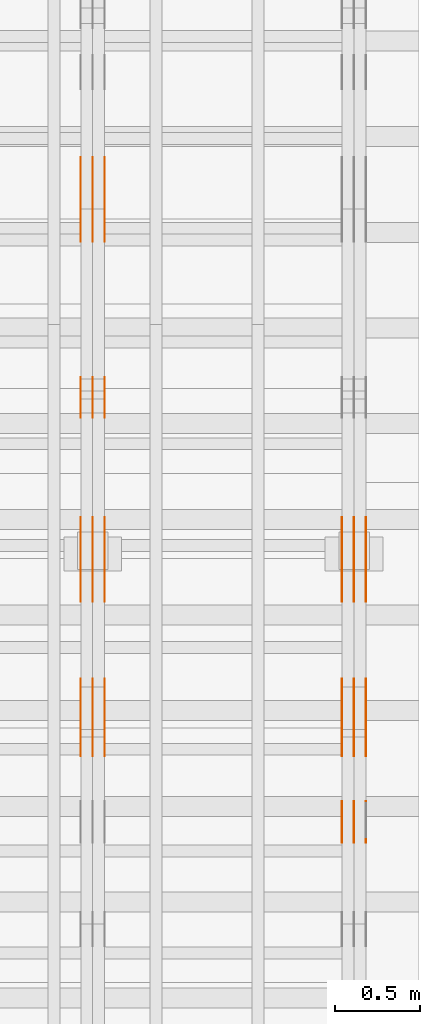
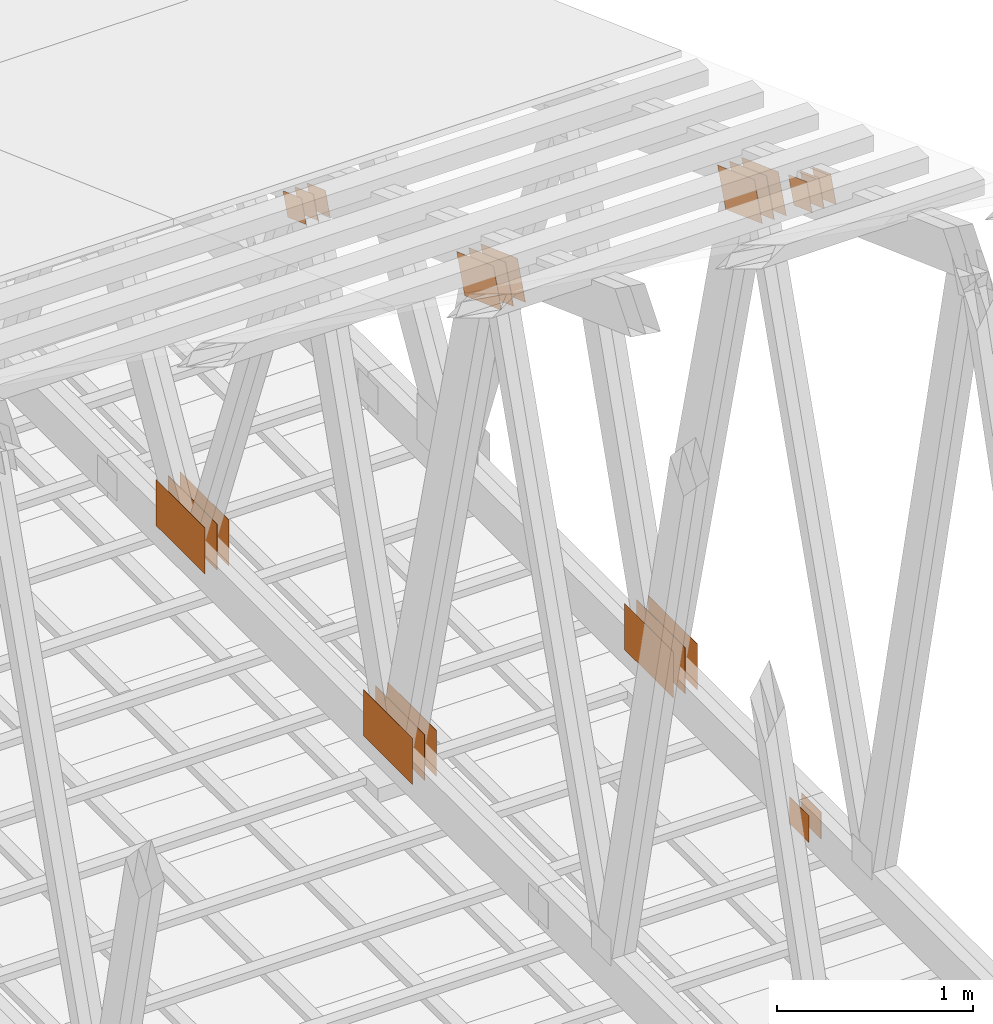
# One storey, part 174 of 189: 31 proxies.
"""IFC2X3 building model written with IfcOpenShell, lengths in millimetres."""

from ifc_helpers import new_model, entity, si_unit, converted_unit, derived_unit, direction, frame, origin, origin_2d_with_axis, place, context, subcontext, project, spatial, polyline, rectangle, outline, extrude, source, transform, mapped, material, type_object, type_shapes, element, save


model = new_model("IFC2X3")

# Units and contexts
model_context = context("Model", 3, precision=0.01, world=origin(), true_north=direction((6.12303176911189e-17, 1.0)))
body_context = subcontext(model_context, "Body", "Model", "MODEL_VIEW")
ifc_project = project(units=[si_unit("LENGTHUNIT", "METRE", prefix="MILLI"), si_unit("AREAUNIT", "SQUARE_METRE"), si_unit("VOLUMEUNIT", "CUBIC_METRE"), converted_unit("PLANEANGLEUNIT", "DEGREE", entity("IfcRatioMeasure", 0.0174532925199433), si_unit("PLANEANGLEUNIT", "RADIAN"), dimensions=[0, 0, 0, 0, 0, 0, 0]), si_unit("MASSUNIT", "GRAM", prefix="KILO"), derived_unit("MASSDENSITYUNIT", [(si_unit("MASSUNIT", "GRAM", prefix="KILO"), 1), (si_unit("LENGTHUNIT", "METRE"), -3)]), si_unit("TIMEUNIT", "SECOND"), si_unit("FREQUENCYUNIT", "HERTZ"), si_unit("THERMODYNAMICTEMPERATUREUNIT", "DEGREE_CELSIUS"), derived_unit("THERMALTRANSMITTANCEUNIT", [(si_unit("MASSUNIT", "GRAM", prefix="KILO"), 1), (si_unit("THERMODYNAMICTEMPERATUREUNIT", "KELVIN"), -1), (si_unit("TIMEUNIT", "SECOND"), -3)]), derived_unit("VOLUMETRICFLOWRATEUNIT", [(si_unit("LENGTHUNIT", "METRE"), 3), (si_unit("TIMEUNIT", "SECOND"), -1)]), si_unit("ELECTRICCURRENTUNIT", "AMPERE"), si_unit("ELECTRICVOLTAGEUNIT", "VOLT"), si_unit("POWERUNIT", "WATT"), si_unit("FORCEUNIT", "NEWTON"), si_unit("ILLUMINANCEUNIT", "LUX"), si_unit("LUMINOUSFLUXUNIT", "LUMEN"), si_unit("LUMINOUSINTENSITYUNIT", "CANDELA"), derived_unit("USERDEFINED", [(si_unit("MASSUNIT", "GRAM", prefix="KILO"), -1), (si_unit("LENGTHUNIT", "METRE"), -2), (si_unit("TIMEUNIT", "SECOND"), 3), (si_unit("LUMINOUSFLUXUNIT", "LUMEN"), 1)]), derived_unit("LINEARVELOCITYUNIT", [(si_unit("LENGTHUNIT", "METRE"), 1), (si_unit("TIMEUNIT", "SECOND"), -1)]), si_unit("PRESSUREUNIT", "PASCAL"), derived_unit("USERDEFINED", [(si_unit("LENGTHUNIT", "METRE"), -2), (si_unit("MASSUNIT", "GRAM", prefix="KILO"), 1), (si_unit("TIMEUNIT", "SECOND"), -2)])], contexts=[model_context])

# Site, building, storey
site_placement = place(None, origin())
site = spatial("IfcSite", under=ifc_project, at=site_placement, CompositionType="ELEMENT")
building_placement = place(site_placement, origin())
building = spatial("IfcBuilding", under=site, at=building_placement, CompositionType="ELEMENT")
storey_placement = place(building_placement, origin())
storey = spatial("IfcBuildingStorey", under=building, at=storey_placement, Name="Default", CompositionType="ELEMENT", Elevation=0.0)

# Proxies
ifc_material_1 = material(Name="IfcSurfaceStyle #281764")
building_element_proxy_type_1 = type_object("IfcBuildingElementProxyType", PredefinedType="NOTDEFINED", material=ifc_material_1)
shared_shape_1 = source(origin(), body_context, "Body", "SweptSolid", [
    extrude(outline(polyline([(-200.000344770935, -119.999765965113), (199.999582244654, -119.999765965113), (200.000344770935, 119.999765965113), (-199.999582244653, 119.999765965113), (-200.000344770935, -119.999765965113)])), frame((200.000344770935, 119.999990805307, 0.0), z_axis=(0.0, 0.0, 1.0), x_axis=(-1.0, 0.0, 0.0)), (0.0, 0.0, 1.0), 1.29999999999999),
])
type_shapes(building_element_proxy_type_1, [shared_shape_1])
proxy_1_placement = place(building_placement, frame((49841.3, 19620.1777846684, 3837.77137841443), z_axis=(-1.0, 0.0, 0.0), x_axis=(0.0, 0.939692620785908, -0.342020143325669)))
element("IfcBuildingElementProxy", 1, at=proxy_1_placement, inside=storey, type_object=building_element_proxy_type_1, material=ifc_material_1, context=body_context, shape_type="MappedRepresentation", body=[
    mapped(shared_shape_1, transform((0.0, 0.0, 0.0), scale=1.0)),
])
ifc_material_2 = material(Name="IfcSurfaceStyle #281707")
building_element_proxy_type_2 = type_object("IfcBuildingElementProxyType", PredefinedType="NOTDEFINED", material=ifc_material_2)
shared_shape_2 = source(origin(), body_context, "Body", "SweptSolid", [
    extrude(outline(polyline([(-200.000344770935, -119.999765965113), (199.999582244654, -119.999765965113), (200.000344770935, 119.999765965113), (-199.999582244653, 119.999765965113), (-200.000344770935, -119.999765965113)])), frame((200.000344770935, 119.999990805307, 0.0), z_axis=(0.0, 0.0, 1.0), x_axis=(-1.0, 0.0, 0.0)), (0.0, 0.0, 1.0), 1.29999999999997),
])
type_shapes(building_element_proxy_type_2, [shared_shape_2])
proxy_2_placement = place(building_placement, frame((49770.0, 19620.1777846684, 3837.77137841443), z_axis=(-1.0, 0.0, 0.0), x_axis=(0.0, 0.939692620785908, -0.342020143325669)))
element("IfcBuildingElementProxy", 2, at=proxy_2_placement, inside=storey, type_object=building_element_proxy_type_2, material=ifc_material_2, context=body_context, shape_type="MappedRepresentation", body=[
    mapped(shared_shape_2, transform((0.0, 0.0, 0.0), scale=1.0)),
])
ifc_material_3 = material(Name="IfcSurfaceStyle #281650")
building_element_proxy_type_3 = type_object("IfcBuildingElementProxyType", PredefinedType="NOTDEFINED", material=ifc_material_3)
shared_shape_3 = source(origin(), body_context, "Body", "SweptSolid", [
    extrude(outline(polyline([(-200.000344770935, -119.999765965113), (199.999582244654, -119.999765965113), (200.000344770935, 119.999765965113), (-199.999582244653, 119.999765965113), (-200.000344770935, -119.999765965113)])), frame((200.000344770935, 119.999990805307, 0.0), z_axis=(0.0, 0.0, 1.0), x_axis=(-1.0, 0.0, 0.0)), (0.0, 0.0, 1.0), 1.29999999999997),
])
type_shapes(building_element_proxy_type_3, [shared_shape_3])
proxy_3_placement = place(building_placement, frame((49771.3, 19620.1777846684, 3837.77137841443), z_axis=(-1.0, 0.0, 0.0), x_axis=(0.0, 0.939692620785908, -0.342020143325669)))
element("IfcBuildingElementProxy", 3, at=proxy_3_placement, inside=storey, type_object=building_element_proxy_type_3, material=ifc_material_3, context=body_context, shape_type="MappedRepresentation", body=[
    mapped(shared_shape_3, transform((0.0, 0.0, 0.0), scale=1.0)),
])
ifc_material_4 = material(Name="IfcSurfaceStyle #281593")
building_element_proxy_type_4 = type_object("IfcBuildingElementProxyType", PredefinedType="NOTDEFINED", material=ifc_material_4)
shared_shape_4 = source(origin(), body_context, "Body", "SweptSolid", [
    extrude(outline(polyline([(-200.000344770935, -119.999765965113), (199.999582244654, -119.999765965113), (200.000344770935, 119.999765965113), (-199.999582244653, 119.999765965113), (-200.000344770935, -119.999765965113)])), frame((200.000344770935, 119.999990805307, 0.0), z_axis=(0.0, 0.0, 1.0), x_axis=(-1.0, 0.0, 0.0)), (0.0, 0.0, 1.0), 1.29999999999998),
])
type_shapes(building_element_proxy_type_4, [shared_shape_4])
proxy_4_placement = place(building_placement, frame((49700.0, 19620.1777846684, 3837.77137841443), z_axis=(-1.0, 0.0, 0.0), x_axis=(0.0, 0.939692620785908, -0.342020143325669)))
element("IfcBuildingElementProxy", 4, at=proxy_4_placement, inside=storey, type_object=building_element_proxy_type_4, material=ifc_material_4, context=body_context, shape_type="MappedRepresentation", body=[
    mapped(shared_shape_4, transform((0.0, 0.0, 0.0), scale=1.0)),
])
ifc_material_5 = material(Name="IfcSurfaceStyle #281536")
building_element_proxy_type_5 = type_object("IfcBuildingElementProxyType", PredefinedType="NOTDEFINED", material=ifc_material_5)
shared_shape_5 = source(origin(), body_context, "Body", "SweptSolid", [
    extrude(rectangle(XDim=500.0, YDim=288.0, at=origin_2d_with_axis()), frame((250.0, 144.0, 0.0), z_axis=(0.0, 0.0, 1.0), x_axis=(-1.0, 0.0, 0.0)), (0.0, 0.0, 1.0), 1.29999999999998),
])
type_shapes(building_element_proxy_type_5, [shared_shape_5])
proxy_5_placement = place(building_placement, frame((49841.3, 20948.0908203125, 101.0), z_axis=(-1.0, 0.0, 0.0), x_axis=(0.0, -1.0, 0.0)))
element("IfcBuildingElementProxy", 5, at=proxy_5_placement, inside=storey, type_object=building_element_proxy_type_5, material=ifc_material_5, context=body_context, shape_type="MappedRepresentation", body=[
    mapped(shared_shape_5, transform((0.0, 0.0, 0.0), scale=1.0)),
])
ifc_material_6 = material(Name="IfcSurfaceStyle #281479")
building_element_proxy_type_6 = type_object("IfcBuildingElementProxyType", PredefinedType="NOTDEFINED", material=ifc_material_6)
shared_shape_6 = source(origin(), body_context, "Body", "SweptSolid", [
    extrude(rectangle(XDim=500.0, YDim=288.0, at=origin_2d_with_axis()), frame((250.0, 144.0, 0.0), z_axis=(0.0, 0.0, 1.0), x_axis=(-1.0, 0.0, 0.0)), (0.0, 0.0, 1.0), 1.29999999999997),
])
type_shapes(building_element_proxy_type_6, [shared_shape_6])
proxy_6_placement = place(building_placement, frame((49770.0, 20948.0908203125, 101.0), z_axis=(-1.0, 0.0, 0.0), x_axis=(0.0, -1.0, 0.0)))
element("IfcBuildingElementProxy", 6, at=proxy_6_placement, inside=storey, type_object=building_element_proxy_type_6, material=ifc_material_6, context=body_context, shape_type="MappedRepresentation", body=[
    mapped(shared_shape_6, transform((0.0, 0.0, 0.0), scale=1.0)),
])
ifc_material_7 = material(Name="IfcSurfaceStyle #281422")
building_element_proxy_type_7 = type_object("IfcBuildingElementProxyType", PredefinedType="NOTDEFINED", material=ifc_material_7)
shared_shape_7 = source(origin(), body_context, "Body", "SweptSolid", [
    extrude(rectangle(XDim=500.0, YDim=288.0, at=origin_2d_with_axis()), frame((250.0, 144.0, 0.0), z_axis=(0.0, 0.0, 1.0), x_axis=(-1.0, 0.0, 0.0)), (0.0, 0.0, 1.0), 1.29999999999997),
])
type_shapes(building_element_proxy_type_7, [shared_shape_7])
proxy_7_placement = place(building_placement, frame((49771.3, 20948.0908203125, 101.0), z_axis=(-1.0, 0.0, 0.0), x_axis=(0.0, -1.0, 0.0)))
element("IfcBuildingElementProxy", 7, at=proxy_7_placement, inside=storey, type_object=building_element_proxy_type_7, material=ifc_material_7, context=body_context, shape_type="MappedRepresentation", body=[
    mapped(shared_shape_7, transform((0.0, 0.0, 0.0), scale=1.0)),
])
ifc_material_8 = material(Name="IfcSurfaceStyle #281365")
building_element_proxy_type_8 = type_object("IfcBuildingElementProxyType", PredefinedType="NOTDEFINED", material=ifc_material_8)
shared_shape_8 = source(origin(), body_context, "Body", "SweptSolid", [
    extrude(rectangle(XDim=500.0, YDim=288.0, at=origin_2d_with_axis()), frame((250.0, 144.0, 0.0), z_axis=(0.0, 0.0, 1.0), x_axis=(-1.0, 0.0, 0.0)), (0.0, 0.0, 1.0), 1.29999999999997),
])
type_shapes(building_element_proxy_type_8, [shared_shape_8])
proxy_8_placement = place(building_placement, frame((49700.0, 20948.0908203125, 101.0), z_axis=(-1.0, 0.0, 0.0), x_axis=(0.0, -1.0, 0.0)))
element("IfcBuildingElementProxy", 8, at=proxy_8_placement, inside=storey, type_object=building_element_proxy_type_8, material=ifc_material_8, context=body_context, shape_type="MappedRepresentation", body=[
    mapped(shared_shape_8, transform((0.0, 0.0, 0.0), scale=1.0)),
])
ifc_material_9 = material(Name="IfcSurfaceStyle #276463")
building_element_proxy_type_9 = type_object("IfcBuildingElementProxyType", PredefinedType="NOTDEFINED", material=ifc_material_9)
shared_shape_9 = source(origin(), body_context, "Body", "SweptSolid", [
    extrude(rectangle(XDim=200.0, YDim=168.0, at=origin_2d_with_axis()), frame((100.0, 84.0, 0.0), z_axis=(0.0, 0.0, 1.0), x_axis=(-1.0, 0.0, 0.0)), (0.0, 0.0, 1.0), 1.29999999999998),
])
type_shapes(building_element_proxy_type_9, [shared_shape_9])
proxy_9_placement = place(building_placement, frame((49770.0, 19061.7587890625, 206.5), z_axis=(-1.0, 0.0, 0.0), x_axis=(0.0, 1.0, 0.0)))
element("IfcBuildingElementProxy", 9, at=proxy_9_placement, inside=storey, type_object=building_element_proxy_type_9, material=ifc_material_9, context=body_context, shape_type="MappedRepresentation", body=[
    mapped(shared_shape_9, transform((0.0, 0.0, 0.0), scale=1.0)),
])
ifc_material_10 = material(Name="IfcSurfaceStyle #276406")
building_element_proxy_type_10 = type_object("IfcBuildingElementProxyType", PredefinedType="NOTDEFINED", material=ifc_material_10)
shared_shape_10 = source(origin(), body_context, "Body", "SweptSolid", [
    extrude(rectangle(XDim=200.0, YDim=168.0, at=origin_2d_with_axis()), frame((100.0, 84.0, 0.0), z_axis=(0.0, 0.0, 1.0), x_axis=(-1.0, 0.0, 0.0)), (0.0, 0.0, 1.0), 1.29999999999998),
])
type_shapes(building_element_proxy_type_10, [shared_shape_10])
proxy_10_placement = place(building_placement, frame((49771.3, 19061.7587890625, 206.5), z_axis=(-1.0, 0.0, 0.0), x_axis=(0.0, 1.0, 0.0)))
element("IfcBuildingElementProxy", 10, at=proxy_10_placement, inside=storey, type_object=building_element_proxy_type_10, material=ifc_material_10, context=body_context, shape_type="MappedRepresentation", body=[
    mapped(shared_shape_10, transform((0.0, 0.0, 0.0), scale=1.0)),
])
ifc_material_11 = material(Name="IfcSurfaceStyle #276349")
building_element_proxy_type_11 = type_object("IfcBuildingElementProxyType", PredefinedType="NOTDEFINED", material=ifc_material_11)
shared_shape_11 = source(origin(), body_context, "Body", "SweptSolid", [
    extrude(rectangle(XDim=200.0, YDim=168.0, at=origin_2d_with_axis()), frame((100.0, 84.0, 0.0), z_axis=(0.0, 0.0, 1.0), x_axis=(-1.0, 0.0, 0.0)), (0.0, 0.0, 1.0), 1.29999999999999),
])
type_shapes(building_element_proxy_type_11, [shared_shape_11])
proxy_11_placement = place(building_placement, frame((49700.0, 19061.7587890625, 206.5), z_axis=(-1.0, 0.0, 0.0), x_axis=(0.0, 1.0, 0.0)))
element("IfcBuildingElementProxy", 11, at=proxy_11_placement, inside=storey, type_object=building_element_proxy_type_11, material=ifc_material_11, context=body_context, shape_type="MappedRepresentation", body=[
    mapped(shared_shape_11, transform((0.0, 0.0, 0.0), scale=1.0)),
])
ifc_material_12 = material(Name="IfcSurfaceStyle #274360")
building_element_proxy_type_12 = type_object("IfcBuildingElementProxyType", PredefinedType="NOTDEFINED", material=ifc_material_12)
shared_shape_12 = source(origin(), body_context, "Body", "SweptSolid", [
    extrude(outline(polyline([(-100.000115120732, -83.9999347094754), (99.9997648860521, -83.9999347094754), (100.000156871236, 83.9999347094753), (-99.9998066365565, 83.9999347094753), (-100.000115120732, -83.9999347094754)])), frame((100.000156871236, 84.0000502182443, 0.0), z_axis=(0.0, 0.0, 1.0), x_axis=(-1.0, 0.0, 0.0)), (0.0, 0.0, 1.0), 1.3),
])
type_shapes(building_element_proxy_type_12, [shared_shape_12])
proxy_12_placement = place(building_placement, frame((49841.3, 19216.0995831719, 3923.28093386695), z_axis=(-1.0, 0.0, 0.0), x_axis=(0.0, -0.939692620785908, 0.342020143325669)))
element("IfcBuildingElementProxy", 12, at=proxy_12_placement, inside=storey, type_object=building_element_proxy_type_12, material=ifc_material_12, context=body_context, shape_type="MappedRepresentation", body=[
    mapped(shared_shape_12, transform((0.0, 0.0, 0.0), scale=1.0)),
])
ifc_material_13 = material(Name="IfcSurfaceStyle #274303")
building_element_proxy_type_13 = type_object("IfcBuildingElementProxyType", PredefinedType="NOTDEFINED", material=ifc_material_13)
shared_shape_13 = source(origin(), body_context, "Body", "SweptSolid", [
    extrude(outline(polyline([(-100.000115120732, -83.9999347094754), (99.9997648860521, -83.9999347094754), (100.000156871236, 83.9999347094753), (-99.9998066365565, 83.9999347094753), (-100.000115120732, -83.9999347094754)])), frame((100.000156871236, 84.0000502182443, 0.0), z_axis=(0.0, 0.0, 1.0), x_axis=(-1.0, 0.0, 0.0)), (0.0, 0.0, 1.0), 1.29999999999998),
])
type_shapes(building_element_proxy_type_13, [shared_shape_13])
proxy_13_placement = place(building_placement, frame((49770.0, 19216.0995831719, 3923.28093386695), z_axis=(-1.0, 0.0, 0.0), x_axis=(0.0, -0.939692620785908, 0.342020143325669)))
element("IfcBuildingElementProxy", 13, at=proxy_13_placement, inside=storey, type_object=building_element_proxy_type_13, material=ifc_material_13, context=body_context, shape_type="MappedRepresentation", body=[
    mapped(shared_shape_13, transform((0.0, 0.0, 0.0), scale=1.0)),
])
ifc_material_14 = material(Name="IfcSurfaceStyle #274246")
building_element_proxy_type_14 = type_object("IfcBuildingElementProxyType", PredefinedType="NOTDEFINED", material=ifc_material_14)
shared_shape_14 = source(origin(), body_context, "Body", "SweptSolid", [
    extrude(outline(polyline([(-100.000115120732, -83.9999347094754), (99.9997648860521, -83.9999347094754), (100.000156871236, 83.9999347094753), (-99.9998066365565, 83.9999347094753), (-100.000115120732, -83.9999347094754)])), frame((100.000156871236, 84.0000502182443, 0.0), z_axis=(0.0, 0.0, 1.0), x_axis=(-1.0, 0.0, 0.0)), (0.0, 0.0, 1.0), 1.29999999999998),
])
type_shapes(building_element_proxy_type_14, [shared_shape_14])
proxy_14_placement = place(building_placement, frame((49771.3, 19216.0995831719, 3923.28093386695), z_axis=(-1.0, 0.0, 0.0), x_axis=(0.0, -0.939692620785908, 0.342020143325669)))
element("IfcBuildingElementProxy", 14, at=proxy_14_placement, inside=storey, type_object=building_element_proxy_type_14, material=ifc_material_14, context=body_context, shape_type="MappedRepresentation", body=[
    mapped(shared_shape_14, transform((0.0, 0.0, 0.0), scale=1.0)),
])
ifc_material_15 = material(Name="IfcSurfaceStyle #274189")
building_element_proxy_type_15 = type_object("IfcBuildingElementProxyType", PredefinedType="NOTDEFINED", material=ifc_material_15)
shared_shape_15 = source(origin(), body_context, "Body", "SweptSolid", [
    extrude(outline(polyline([(-100.000115120732, -83.9999347094754), (99.9997648860521, -83.9999347094754), (100.000156871236, 83.9999347094753), (-99.9998066365565, 83.9999347094753), (-100.000115120732, -83.9999347094754)])), frame((100.000156871236, 84.0000502182443, 0.0), z_axis=(0.0, 0.0, 1.0), x_axis=(-1.0, 0.0, 0.0)), (0.0, 0.0, 1.0), 1.29999999999999),
])
type_shapes(building_element_proxy_type_15, [shared_shape_15])
proxy_15_placement = place(building_placement, frame((49700.0, 19216.0995831719, 3923.28093386695), z_axis=(-1.0, 0.0, 0.0), x_axis=(0.0, -0.939692620785908, 0.342020143325669)))
element("IfcBuildingElementProxy", 15, at=proxy_15_placement, inside=storey, type_object=building_element_proxy_type_15, material=ifc_material_15, context=body_context, shape_type="MappedRepresentation", body=[
    mapped(shared_shape_15, transform((0.0, 0.0, 0.0), scale=1.0)),
])
ifc_material_16 = material(Name="IfcSurfaceStyle #265974")
building_element_proxy_type_16 = type_object("IfcBuildingElementProxyType", PredefinedType="NOTDEFINED", material=ifc_material_16)
shared_shape_16 = source(origin(), body_context, "Body", "SweptSolid", [
    extrude(outline(polyline([(-200.000344770935, -119.999765965113), (199.999582244654, -119.999765965113), (200.000344770935, 119.999765965113), (-199.999582244653, 119.999765965113), (-200.000344770935, -119.999765965113)])), frame((200.000344770935, 119.999990805307, 0.0), z_axis=(0.0, 0.0, 1.0), x_axis=(-1.0, 0.0, 0.0)), (0.0, 0.0, 1.0), 1.29999999999999),
])
type_shapes(building_element_proxy_type_16, [shared_shape_16])
proxy_16_placement = place(building_placement, frame((48301.3, 19620.1777846684, 3837.77137841443), z_axis=(-1.0, 0.0, 0.0), x_axis=(0.0, 0.939692620785908, -0.342020143325669)))
element("IfcBuildingElementProxy", 16, at=proxy_16_placement, inside=storey, type_object=building_element_proxy_type_16, material=ifc_material_16, context=body_context, shape_type="MappedRepresentation", body=[
    mapped(shared_shape_16, transform((0.0, 0.0, 0.0), scale=1.0)),
])
ifc_material_17 = material(Name="IfcSurfaceStyle #265917")
building_element_proxy_type_17 = type_object("IfcBuildingElementProxyType", PredefinedType="NOTDEFINED", material=ifc_material_17)
shared_shape_17 = source(origin(), body_context, "Body", "SweptSolid", [
    extrude(outline(polyline([(-200.000344770935, -119.999765965113), (199.999582244654, -119.999765965113), (200.000344770935, 119.999765965113), (-199.999582244653, 119.999765965113), (-200.000344770935, -119.999765965113)])), frame((200.000344770935, 119.999990805307, 0.0), z_axis=(0.0, 0.0, 1.0), x_axis=(-1.0, 0.0, 0.0)), (0.0, 0.0, 1.0), 1.29999999999997),
])
type_shapes(building_element_proxy_type_17, [shared_shape_17])
proxy_17_placement = place(building_placement, frame((48230.0, 19620.1777846684, 3837.77137841443), z_axis=(-1.0, 0.0, 0.0), x_axis=(0.0, 0.939692620785908, -0.342020143325669)))
element("IfcBuildingElementProxy", 17, at=proxy_17_placement, inside=storey, type_object=building_element_proxy_type_17, material=ifc_material_17, context=body_context, shape_type="MappedRepresentation", body=[
    mapped(shared_shape_17, transform((0.0, 0.0, 0.0), scale=1.0)),
])
ifc_material_18 = material(Name="IfcSurfaceStyle #265860")
building_element_proxy_type_18 = type_object("IfcBuildingElementProxyType", PredefinedType="NOTDEFINED", material=ifc_material_18)
shared_shape_18 = source(origin(), body_context, "Body", "SweptSolid", [
    extrude(outline(polyline([(-200.000344770935, -119.999765965113), (199.999582244654, -119.999765965113), (200.000344770935, 119.999765965113), (-199.999582244653, 119.999765965113), (-200.000344770935, -119.999765965113)])), frame((200.000344770935, 119.999990805307, 0.0), z_axis=(0.0, 0.0, 1.0), x_axis=(-1.0, 0.0, 0.0)), (0.0, 0.0, 1.0), 1.29999999999997),
])
type_shapes(building_element_proxy_type_18, [shared_shape_18])
proxy_18_placement = place(building_placement, frame((48231.3, 19620.1777846684, 3837.77137841443), z_axis=(-1.0, 0.0, 0.0), x_axis=(0.0, 0.939692620785908, -0.342020143325669)))
element("IfcBuildingElementProxy", 18, at=proxy_18_placement, inside=storey, type_object=building_element_proxy_type_18, material=ifc_material_18, context=body_context, shape_type="MappedRepresentation", body=[
    mapped(shared_shape_18, transform((0.0, 0.0, 0.0), scale=1.0)),
])
ifc_material_19 = material(Name="IfcSurfaceStyle #265803")
building_element_proxy_type_19 = type_object("IfcBuildingElementProxyType", PredefinedType="NOTDEFINED", material=ifc_material_19)
shared_shape_19 = source(origin(), body_context, "Body", "SweptSolid", [
    extrude(outline(polyline([(-200.000344770935, -119.999765965113), (199.999582244654, -119.999765965113), (200.000344770935, 119.999765965113), (-199.999582244653, 119.999765965113), (-200.000344770935, -119.999765965113)])), frame((200.000344770935, 119.999990805307, 0.0), z_axis=(0.0, 0.0, 1.0), x_axis=(-1.0, 0.0, 0.0)), (0.0, 0.0, 1.0), 1.29999999999998),
])
type_shapes(building_element_proxy_type_19, [shared_shape_19])
proxy_19_placement = place(building_placement, frame((48160.0, 19620.1777846684, 3837.77137841443), z_axis=(-1.0, 0.0, 0.0), x_axis=(0.0, 0.939692620785908, -0.342020143325669)))
element("IfcBuildingElementProxy", 19, at=proxy_19_placement, inside=storey, type_object=building_element_proxy_type_19, material=ifc_material_19, context=body_context, shape_type="MappedRepresentation", body=[
    mapped(shared_shape_19, transform((0.0, 0.0, 0.0), scale=1.0)),
])
ifc_material_20 = material(Name="IfcSurfaceStyle #265746")
building_element_proxy_type_20 = type_object("IfcBuildingElementProxyType", PredefinedType="NOTDEFINED", material=ifc_material_20)
shared_shape_20 = source(origin(), body_context, "Body", "SweptSolid", [
    extrude(rectangle(XDim=500.0, YDim=288.0, at=origin_2d_with_axis()), frame((250.0, 144.0, 0.0), z_axis=(0.0, 0.0, 1.0), x_axis=(-1.0, 0.0, 0.0)), (0.0, 0.0, 1.0), 1.29999999999998),
])
type_shapes(building_element_proxy_type_20, [shared_shape_20])
proxy_20_placement = place(building_placement, frame((48301.3, 20948.0908203125, 101.0), z_axis=(-1.0, 0.0, 0.0), x_axis=(0.0, -1.0, 0.0)))
element("IfcBuildingElementProxy", 20, at=proxy_20_placement, inside=storey, type_object=building_element_proxy_type_20, material=ifc_material_20, context=body_context, shape_type="MappedRepresentation", body=[
    mapped(shared_shape_20, transform((0.0, 0.0, 0.0), scale=1.0)),
])
ifc_material_21 = material(Name="IfcSurfaceStyle #265689")
building_element_proxy_type_21 = type_object("IfcBuildingElementProxyType", PredefinedType="NOTDEFINED", material=ifc_material_21)
shared_shape_21 = source(origin(), body_context, "Body", "SweptSolid", [
    extrude(rectangle(XDim=500.0, YDim=288.0, at=origin_2d_with_axis()), frame((250.0, 144.0, 0.0), z_axis=(0.0, 0.0, 1.0), x_axis=(-1.0, 0.0, 0.0)), (0.0, 0.0, 1.0), 1.29999999999997),
])
type_shapes(building_element_proxy_type_21, [shared_shape_21])
proxy_21_placement = place(building_placement, frame((48230.0, 20948.0908203125, 101.0), z_axis=(-1.0, 0.0, 0.0), x_axis=(0.0, -1.0, 0.0)))
element("IfcBuildingElementProxy", 21, at=proxy_21_placement, inside=storey, type_object=building_element_proxy_type_21, material=ifc_material_21, context=body_context, shape_type="MappedRepresentation", body=[
    mapped(shared_shape_21, transform((0.0, 0.0, 0.0), scale=1.0)),
])
ifc_material_22 = material(Name="IfcSurfaceStyle #265632")
building_element_proxy_type_22 = type_object("IfcBuildingElementProxyType", PredefinedType="NOTDEFINED", material=ifc_material_22)
shared_shape_22 = source(origin(), body_context, "Body", "SweptSolid", [
    extrude(rectangle(XDim=500.0, YDim=288.0, at=origin_2d_with_axis()), frame((250.0, 144.0, 0.0), z_axis=(0.0, 0.0, 1.0), x_axis=(-1.0, 0.0, 0.0)), (0.0, 0.0, 1.0), 1.29999999999997),
])
type_shapes(building_element_proxy_type_22, [shared_shape_22])
proxy_22_placement = place(building_placement, frame((48231.3, 20948.0908203125, 101.0), z_axis=(-1.0, 0.0, 0.0), x_axis=(0.0, -1.0, 0.0)))
element("IfcBuildingElementProxy", 22, at=proxy_22_placement, inside=storey, type_object=building_element_proxy_type_22, material=ifc_material_22, context=body_context, shape_type="MappedRepresentation", body=[
    mapped(shared_shape_22, transform((0.0, 0.0, 0.0), scale=1.0)),
])
ifc_material_23 = material(Name="IfcSurfaceStyle #265575")
building_element_proxy_type_23 = type_object("IfcBuildingElementProxyType", PredefinedType="NOTDEFINED", material=ifc_material_23)
shared_shape_23 = source(origin(), body_context, "Body", "SweptSolid", [
    extrude(rectangle(XDim=500.0, YDim=288.0, at=origin_2d_with_axis()), frame((250.0, 144.0, 0.0), z_axis=(0.0, 0.0, 1.0), x_axis=(-1.0, 0.0, 0.0)), (0.0, 0.0, 1.0), 1.29999999999997),
])
type_shapes(building_element_proxy_type_23, [shared_shape_23])
proxy_23_placement = place(building_placement, frame((48160.0, 20948.0908203125, 101.0), z_axis=(-1.0, 0.0, 0.0), x_axis=(0.0, -1.0, 0.0)))
element("IfcBuildingElementProxy", 23, at=proxy_23_placement, inside=storey, type_object=building_element_proxy_type_23, material=ifc_material_23, context=body_context, shape_type="MappedRepresentation", body=[
    mapped(shared_shape_23, transform((0.0, 0.0, 0.0), scale=1.0)),
])
ifc_material_24 = material(Name="IfcSurfaceStyle #265062")
building_element_proxy_type_24 = type_object("IfcBuildingElementProxyType", PredefinedType="NOTDEFINED", material=ifc_material_24)
shared_shape_24 = source(origin(), body_context, "Body", "SweptSolid", [
    extrude(outline(polyline([(-100.000279336925, -71.9999636698844), (100.000143005157, -71.9999636698844), (100.00004991978, 71.9999636698844), (-99.9999135880125, 71.9999636698845), (-100.000279336925, -71.9999636698844)])), frame((100.000143005157, 72.0001110824169, 0.0), z_axis=(0.0, 0.0, 1.0), x_axis=(-1.0, 0.0, 0.0)), (0.0, 0.0, 1.0), 1.3),
])
type_shapes(building_element_proxy_type_24, [shared_shape_24])
proxy_24_placement = place(building_placement, frame((48301.3, 21584.0819808932, 3071.51551466861), z_axis=(-1.0, 0.0, 0.0), x_axis=(0.0, 0.939692620785908, -0.342020143325669)))
element("IfcBuildingElementProxy", 24, at=proxy_24_placement, inside=storey, type_object=building_element_proxy_type_24, material=ifc_material_24, context=body_context, shape_type="MappedRepresentation", body=[
    mapped(shared_shape_24, transform((0.0, 0.0, 0.0), scale=1.0)),
])
ifc_material_25 = material(Name="IfcSurfaceStyle #265005")
building_element_proxy_type_25 = type_object("IfcBuildingElementProxyType", PredefinedType="NOTDEFINED", material=ifc_material_25)
shared_shape_25 = source(origin(), body_context, "Body", "SweptSolid", [
    extrude(outline(polyline([(-100.000279336925, -71.9999636698844), (100.000143005157, -71.9999636698844), (100.00004991978, 71.9999636698844), (-99.9999135880125, 71.9999636698845), (-100.000279336925, -71.9999636698844)])), frame((100.000143005157, 72.0001110824169, 0.0), z_axis=(0.0, 0.0, 1.0), x_axis=(-1.0, 0.0, 0.0)), (0.0, 0.0, 1.0), 1.29999999999998),
])
type_shapes(building_element_proxy_type_25, [shared_shape_25])
proxy_25_placement = place(building_placement, frame((48230.0, 21584.0819808932, 3071.51551466861), z_axis=(-1.0, 0.0, 0.0), x_axis=(0.0, 0.939692620785908, -0.342020143325669)))
element("IfcBuildingElementProxy", 25, at=proxy_25_placement, inside=storey, type_object=building_element_proxy_type_25, material=ifc_material_25, context=body_context, shape_type="MappedRepresentation", body=[
    mapped(shared_shape_25, transform((0.0, 0.0, 0.0), scale=1.0)),
])
ifc_material_26 = material(Name="IfcSurfaceStyle #264948")
building_element_proxy_type_26 = type_object("IfcBuildingElementProxyType", PredefinedType="NOTDEFINED", material=ifc_material_26)
shared_shape_26 = source(origin(), body_context, "Body", "SweptSolid", [
    extrude(outline(polyline([(-100.000279336925, -71.9999636698844), (100.000143005157, -71.9999636698844), (100.00004991978, 71.9999636698844), (-99.9999135880125, 71.9999636698845), (-100.000279336925, -71.9999636698844)])), frame((100.000143005157, 72.0001110824169, 0.0), z_axis=(0.0, 0.0, 1.0), x_axis=(-1.0, 0.0, 0.0)), (0.0, 0.0, 1.0), 1.29999999999998),
])
type_shapes(building_element_proxy_type_26, [shared_shape_26])
proxy_26_placement = place(building_placement, frame((48231.3, 21584.0819808932, 3071.51551466861), z_axis=(-1.0, 0.0, 0.0), x_axis=(0.0, 0.939692620785908, -0.342020143325669)))
element("IfcBuildingElementProxy", 26, at=proxy_26_placement, inside=storey, type_object=building_element_proxy_type_26, material=ifc_material_26, context=body_context, shape_type="MappedRepresentation", body=[
    mapped(shared_shape_26, transform((0.0, 0.0, 0.0), scale=1.0)),
])
ifc_material_27 = material(Name="IfcSurfaceStyle #264891")
building_element_proxy_type_27 = type_object("IfcBuildingElementProxyType", PredefinedType="NOTDEFINED", material=ifc_material_27)
shared_shape_27 = source(origin(), body_context, "Body", "SweptSolid", [
    extrude(outline(polyline([(-100.000279336925, -71.9999636698844), (100.000143005157, -71.9999636698844), (100.00004991978, 71.9999636698844), (-99.9999135880125, 71.9999636698845), (-100.000279336925, -71.9999636698844)])), frame((100.000143005157, 72.0001110824169, 0.0), z_axis=(0.0, 0.0, 1.0), x_axis=(-1.0, 0.0, 0.0)), (0.0, 0.0, 1.0), 1.29999999999999),
])
type_shapes(building_element_proxy_type_27, [shared_shape_27])
proxy_27_placement = place(building_placement, frame((48160.0, 21584.0819808932, 3071.51551466861), z_axis=(-1.0, 0.0, 0.0), x_axis=(0.0, 0.939692620785908, -0.342020143325669)))
element("IfcBuildingElementProxy", 27, at=proxy_27_placement, inside=storey, type_object=building_element_proxy_type_27, material=ifc_material_27, context=body_context, shape_type="MappedRepresentation", body=[
    mapped(shared_shape_27, transform((0.0, 0.0, 0.0), scale=1.0)),
])
ifc_material_28 = material(Name="IfcSurfaceStyle #264834")
building_element_proxy_type_28 = type_object("IfcBuildingElementProxyType", PredefinedType="NOTDEFINED", material=ifc_material_28)
shared_shape_28 = source(origin(), body_context, "Body", "SweptSolid", [
    extrude(rectangle(XDim=500.0, YDim=288.000007629395, at=origin_2d_with_axis()), frame((250.000021301719, 144.000006357829, 0.0), z_axis=(0.0, 0.0, 1.0), x_axis=(-1.0, 0.0, 0.0)), (0.0, 0.0, 1.0), 1.29999999999998),
])
type_shapes(building_element_proxy_type_28, [shared_shape_28])
proxy_28_placement = place(building_placement, frame((48301.3, 23069.1650603642, 127.333333333333), z_axis=(-1.0, 0.0, 0.0), x_axis=(0.0, -1.0, 0.0)))
element("IfcBuildingElementProxy", 28, at=proxy_28_placement, inside=storey, type_object=building_element_proxy_type_28, material=ifc_material_28, context=body_context, shape_type="MappedRepresentation", body=[
    mapped(shared_shape_28, transform((0.0, 0.0, 0.0), scale=1.0)),
])
ifc_material_29 = material(Name="IfcSurfaceStyle #264777")
building_element_proxy_type_29 = type_object("IfcBuildingElementProxyType", PredefinedType="NOTDEFINED", material=ifc_material_29)
shared_shape_29 = source(origin(), body_context, "Body", "SweptSolid", [
    extrude(rectangle(XDim=500.0, YDim=288.000007629395, at=origin_2d_with_axis()), frame((250.000021301719, 144.000006357829, 0.0), z_axis=(0.0, 0.0, 1.0), x_axis=(-1.0, 0.0, 0.0)), (0.0, 0.0, 1.0), 1.29999999999997),
])
type_shapes(building_element_proxy_type_29, [shared_shape_29])
proxy_29_placement = place(building_placement, frame((48230.0, 23069.1650603642, 127.333333333333), z_axis=(-1.0, 0.0, 0.0), x_axis=(0.0, -1.0, 0.0)))
element("IfcBuildingElementProxy", 29, at=proxy_29_placement, inside=storey, type_object=building_element_proxy_type_29, material=ifc_material_29, context=body_context, shape_type="MappedRepresentation", body=[
    mapped(shared_shape_29, transform((0.0, 0.0, 0.0), scale=1.0)),
])
ifc_material_30 = material(Name="IfcSurfaceStyle #264720")
building_element_proxy_type_30 = type_object("IfcBuildingElementProxyType", PredefinedType="NOTDEFINED", material=ifc_material_30)
shared_shape_30 = source(origin(), body_context, "Body", "SweptSolid", [
    extrude(rectangle(XDim=500.0, YDim=288.000007629395, at=origin_2d_with_axis()), frame((250.000021301719, 144.000006357829, 0.0), z_axis=(0.0, 0.0, 1.0), x_axis=(-1.0, 0.0, 0.0)), (0.0, 0.0, 1.0), 1.29999999999997),
])
type_shapes(building_element_proxy_type_30, [shared_shape_30])
proxy_30_placement = place(building_placement, frame((48231.3, 23069.1650603642, 127.333333333333), z_axis=(-1.0, 0.0, 0.0), x_axis=(0.0, -1.0, 0.0)))
element("IfcBuildingElementProxy", 30, at=proxy_30_placement, inside=storey, type_object=building_element_proxy_type_30, material=ifc_material_30, context=body_context, shape_type="MappedRepresentation", body=[
    mapped(shared_shape_30, transform((0.0, 0.0, 0.0), scale=1.0)),
])
ifc_material_31 = material(Name="IfcSurfaceStyle #264663")
building_element_proxy_type_31 = type_object("IfcBuildingElementProxyType", PredefinedType="NOTDEFINED", material=ifc_material_31)
shared_shape_31 = source(origin(), body_context, "Body", "SweptSolid", [
    extrude(rectangle(XDim=500.0, YDim=288.000007629395, at=origin_2d_with_axis()), frame((250.000021301719, 144.000006357829, 0.0), z_axis=(0.0, 0.0, 1.0), x_axis=(-1.0, 0.0, 0.0)), (0.0, 0.0, 1.0), 1.29999999999997),
])
type_shapes(building_element_proxy_type_31, [shared_shape_31])
proxy_31_placement = place(building_placement, frame((48160.0, 23069.1650603642, 127.333333333333), z_axis=(-1.0, 0.0, 0.0), x_axis=(0.0, -1.0, 0.0)))
element("IfcBuildingElementProxy", 31, at=proxy_31_placement, inside=storey, type_object=building_element_proxy_type_31, material=ifc_material_31, context=body_context, shape_type="MappedRepresentation", body=[
    mapped(shared_shape_31, transform((0.0, 0.0, 0.0), scale=1.0)),
])

save(model, "model.ifc")
